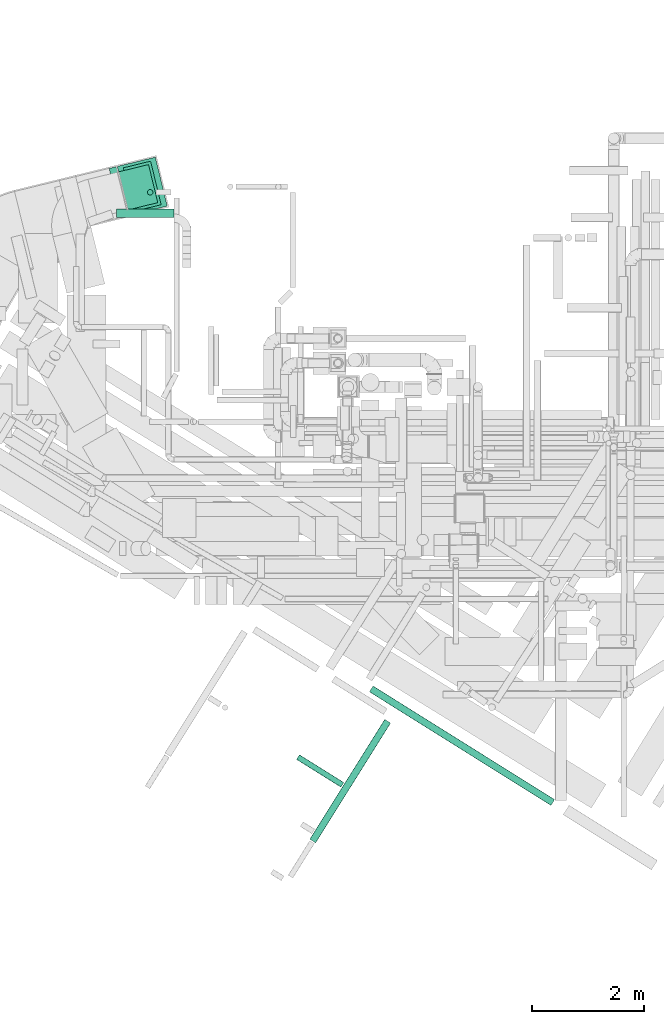
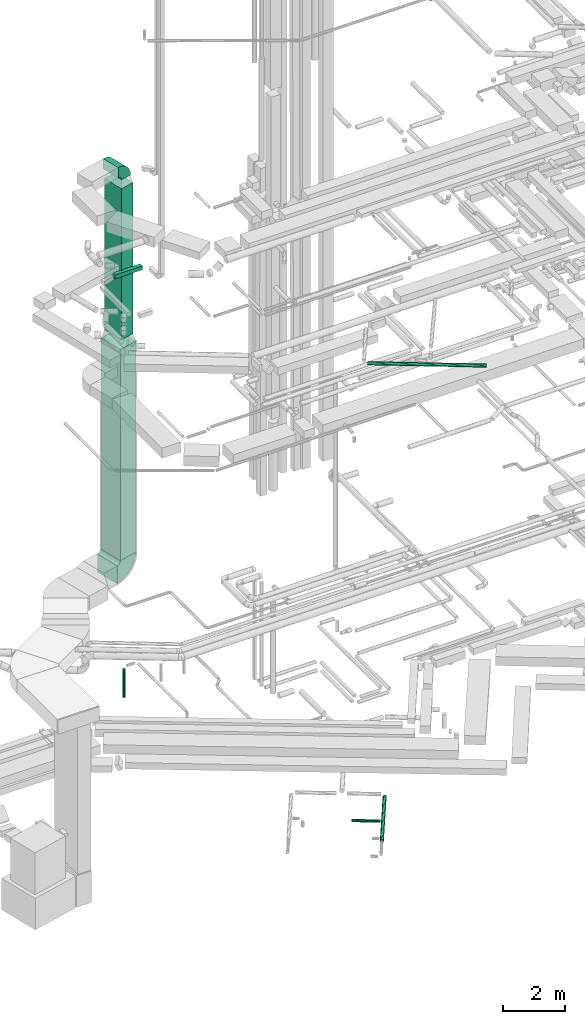
# One storey, part 24 of 337: 7 flow segments, 2 flow fittings.
"""IFC2X3 building model written with IfcOpenShell, lengths in millimetres."""

from ifc_helpers import new_model, entity, si_unit, converted_unit, derived_unit, direction, frame, frame_2d, origin, origin_2d_with_axis, place, context, subcontext, project, spatial, polyline, circle_curve, parameter, trimmed, segment, composite_curve, rectangle, circle, outline, extrude, source, transform, mapped, material, type_object, type_shapes, element, save


model = new_model("IFC2X3")

# Units and contexts
model_context = context("Model", 3, precision=0.01, world=origin(), true_north=direction((6.12303176911189e-17, 1.0)))
body_context = subcontext(model_context, "Body", "Model", "MODEL_VIEW")
ifc_project = project(units=[si_unit("LENGTHUNIT", "METRE", prefix="MILLI"), si_unit("AREAUNIT", "SQUARE_METRE"), si_unit("VOLUMEUNIT", "CUBIC_METRE"), converted_unit("PLANEANGLEUNIT", "DEGREE", entity("IfcRatioMeasure", 0.0174532925199433), si_unit("PLANEANGLEUNIT", "RADIAN"), dimensions=[0, 0, 0, 0, 0, 0, 0]), si_unit("MASSUNIT", "GRAM", prefix="KILO"), derived_unit("MASSDENSITYUNIT", [(si_unit("MASSUNIT", "GRAM", prefix="KILO"), 1), (si_unit("LENGTHUNIT", "METRE"), -3)]), derived_unit("MOMENTOFINERTIAUNIT", [(si_unit("LENGTHUNIT", "METRE"), 4)]), si_unit("TIMEUNIT", "SECOND"), si_unit("FREQUENCYUNIT", "HERTZ"), si_unit("THERMODYNAMICTEMPERATUREUNIT", "DEGREE_CELSIUS"), derived_unit("THERMALTRANSMITTANCEUNIT", [(si_unit("MASSUNIT", "GRAM", prefix="KILO"), 1), (si_unit("THERMODYNAMICTEMPERATUREUNIT", "KELVIN"), -1), (si_unit("TIMEUNIT", "SECOND"), -3)]), derived_unit("VOLUMETRICFLOWRATEUNIT", [(si_unit("LENGTHUNIT", "METRE"), 3), (si_unit("TIMEUNIT", "SECOND"), -1)]), derived_unit("MASSFLOWRATEUNIT", [(si_unit("MASSUNIT", "GRAM", prefix="KILO"), 1), (si_unit("TIMEUNIT", "SECOND"), -1)]), derived_unit("ROTATIONALFREQUENCYUNIT", [(si_unit("TIMEUNIT", "SECOND"), -1)]), si_unit("ELECTRICCURRENTUNIT", "AMPERE"), si_unit("ELECTRICVOLTAGEUNIT", "VOLT"), si_unit("POWERUNIT", "WATT"), si_unit("FORCEUNIT", "NEWTON", prefix="KILO"), si_unit("ILLUMINANCEUNIT", "LUX"), si_unit("LUMINOUSFLUXUNIT", "LUMEN"), si_unit("LUMINOUSINTENSITYUNIT", "CANDELA"), derived_unit("USERDEFINED", [(si_unit("MASSUNIT", "GRAM", prefix="KILO"), -1), (si_unit("LENGTHUNIT", "METRE"), -2), (si_unit("TIMEUNIT", "SECOND"), 3), (si_unit("LUMINOUSFLUXUNIT", "LUMEN"), 1)]), derived_unit("LINEARVELOCITYUNIT", [(si_unit("LENGTHUNIT", "METRE"), 1), (si_unit("TIMEUNIT", "SECOND"), -1)]), si_unit("PRESSUREUNIT", "PASCAL"), derived_unit("USERDEFINED", [(si_unit("LENGTHUNIT", "METRE"), -2), (si_unit("MASSUNIT", "GRAM", prefix="KILO"), 1), (si_unit("TIMEUNIT", "SECOND"), -2)]), derived_unit("LINEARFORCEUNIT", [(si_unit("MASSUNIT", "GRAM", prefix="KILO"), 1), (si_unit("LENGTHUNIT", "METRE"), 1), (si_unit("TIMEUNIT", "SECOND"), -2), (si_unit("LENGTHUNIT", "METRE"), -1)]), derived_unit("PLANARFORCEUNIT", [(si_unit("MASSUNIT", "GRAM", prefix="KILO"), 1), (si_unit("LENGTHUNIT", "METRE"), 1), (si_unit("TIMEUNIT", "SECOND"), -2), (si_unit("LENGTHUNIT", "METRE"), -2)])], contexts=[model_context])

# Site, building, storey
site_placement = place(None, origin())
site = spatial("IfcSite", under=ifc_project, at=site_placement, CompositionType="ELEMENT")
building_placement = place(site_placement, origin())
building = spatial("IfcBuilding", under=site, at=building_placement, CompositionType="ELEMENT")
storey_placement = place(building_placement, origin())
storey = spatial("IfcBuildingStorey", under=building, at=storey_placement, CompositionType="ELEMENT", Elevation=0.0)

# Flow segments
duct_segment_type_1 = type_object("IfcDuctSegmentType", PredefinedType="NOTDEFINED")
flow_segment_1_placement = place(storey_placement, frame((4083.1, 16997.5, 3950.0)))
element("IfcFlowSegment", 1, at=flow_segment_1_placement, inside=storey, type_object=duct_segment_type_1, context=body_context, shape_type="SweptSolid", body=[
    extrude(rectangle(XDim=699.999999999999, YDim=899.999999999999, at=origin_2d_with_axis()), frame((446.61, 520.09, 0.0), z_axis=(0.0, 0.0, 1.0), x_axis=(-0.971552058141474, -0.236826092990332, 0.0)), (0.0, 0.0, 1.0), 8300.00000000007),
])
flow_segment_2_placement = place(storey_placement, frame((4192.1, 17069.76, 12550.0)))
element("IfcFlowSegment", 2, at=flow_segment_2_placement, inside=storey, type_object=duct_segment_type_1, context=body_context, shape_type="SweptSolid", body=[
    extrude(rectangle(XDim=799.999999999999, YDim=500.0, at=origin_2d_with_axis()), frame((337.62, 447.83, 0.0), z_axis=(0.0, 0.0, 1.0), x_axis=(0.236826092990334, -0.971552058141474, 0.0)), (0.0, 0.0, 1.0), 5949.99999999992),
])
flow_segment_3_placement = place(storey_placement, frame((4066.87, 16960.58, 15125.0)))
element("IfcFlowSegment", 3, at=flow_segment_3_placement, inside=storey, type_object=duct_segment_type_1, context=body_context, shape_type="SweptSolid", body=[
    extrude(rectangle(XDim=1032.92560943049, YDim=150.000000000001, at=origin_2d_with_axis()), frame((516.46, 75.0, 0.0), z_axis=(0.0, 0.0, 1.0), x_axis=(-1.0, 0.0, 0.0)), (0.0, 0.0, 1.0), 150.000000000001),
])
duct_segment_type_2 = type_object("IfcDuctSegmentType", PredefinedType="NOTDEFINED")
flow_segment_4_placement = place(storey_placement, frame((4619.42, 17357.26, -1800.0)))
element("IfcFlowSegment", 4, at=flow_segment_4_placement, inside=storey, type_object=duct_segment_type_2, context=body_context, shape_type="SweptSolid", body=[
    extrude(circle(Radius=50.0, at=origin_2d_with_axis()), frame((51.6, 51.6, 0.0), z_axis=(0.0, 0.0, 1.0), x_axis=(0.0, -1.0, 0.0)), (0.0, 0.0, 1.0), 1100.00000000001),
])
flow_segment_5_placement = place(storey_placement, frame((7519.16, 5790.74, -1534.1)))
element("IfcFlowSegment", 5, at=flow_segment_5_placement, inside=storey, type_object=duct_segment_type_2, context=body_context, shape_type="SweptSolid", body=[
    extrude(circle(Radius=62.5, at=origin_2d_with_axis()), frame((54.58, 34.75, 64.1), z_axis=(0.530465285602536, 0.847706659623846, 0.0), x_axis=(-0.847706659623846, 0.530465285602536, 0.0)), (0.0, 0.0, 1.0), 2523.05389240172),
])
flow_segment_6_placement = place(storey_placement, frame((7281.16, 6783.64, -1521.6)))
element("IfcFlowSegment", 6, at=flow_segment_6_placement, inside=storey, type_object=duct_segment_type_2, context=body_context, shape_type="SweptSolid", body=[
    extrude(circle(Radius=50.0, at=origin_2d_with_axis()), frame((28.09, 540.28, 51.6), z_axis=(0.848052743777572, -0.529911826412029, 0.0), x_axis=(0.529911826412029, 0.848052743777572, 0.0)), (0.0, 0.0, 1.0), 936.535742155169),
])
flow_segment_7_placement = place(storey_placement, frame((8583.37, 6458.27, 15260.9)))
element("IfcFlowSegment", 7, at=flow_segment_7_placement, inside=storey, type_object=duct_segment_type_2, context=body_context, shape_type="SweptSolid", body=[
    extrude(circle(Radius=62.5, at=origin_2d_with_axis()), frame((34.75, 2083.3, 64.1), z_axis=(0.847731813922807, -0.530425085816224, 0.0), x_axis=(-0.530425085816224, -0.847731813922807, 0.0)), (0.0, 0.0, 1.0), 3824.70017723322),
])

# Flow fittings
ifc_material = material()
duct_fitting_type_1 = type_object("IfcDuctFittingType", PredefinedType="NOTDEFINED", material=ifc_material)
shared_shape_1 = source(origin(), body_context, "Body", "SweptSolid", [
    extrude(outline(composite_curve([segment(polyline([(-600.0, -250.0), (100.0, -250.0)]), True, "CONTINUOUS"), segment(trimmed(circle_curve(frame_2d((250.0, -250.0), x_axis=(0.0, 1.0)), 150.0), [parameter(0.0)], [parameter(90.0000000000001)], True, "PARAMETER"), False, "CONTINUOUS"), segment(polyline([(250.0, -100.0), (250.0, 600.0)]), True, "CONTINUOUS"), segment(trimmed(circle_curve(frame_2d((250.0, -250.0), x_axis=(0.0, 1.0)), 850.0), [parameter(0.0)], [parameter(90.0)], True, "PARAMETER"), True, "CONTINUOUS")], self_intersect=False)), frame((-250.0, 250.0, -450.0), z_axis=(0.0, 0.0, 1.0), x_axis=(-1.0, 0.0, 0.0)), (0.0, 0.0, 1.0), 900.0),
])
type_shapes(duct_fitting_type_1, [shared_shape_1])
flow_fitting_1_placement = place(storey_placement, frame((4529.72, 17517.59, 3450.0), z_axis=(0.236826092990338, -0.971552058141473, 0.0), x_axis=(0.971552058141473, 0.236826092990338, 0.0)))
element("IfcFlowFitting", 8, at=flow_fitting_1_placement, inside=storey, type_object=duct_fitting_type_1, material=ifc_material, context=body_context, shape_type="MappedRepresentation", body=[
    mapped(shared_shape_1, transform((0.0, 0.0, 0.0), scale=1.0)),
])
duct_fitting_type_2 = type_object("IfcDuctFittingType", PredefinedType="NOTDEFINED", material=ifc_material)
shared_shape_2 = source(origin(), body_context, "Body", "SweptSolid", [
    extrude(outline(composite_curve([segment(polyline([(-375.0, -175.0), (25.0, -175.0)]), True, "CONTINUOUS"), segment(trimmed(circle_curve(frame_2d((175.0, -175.0), x_axis=(0.0, 1.0)), 150.0), [parameter(0.0)], [parameter(90.0000000000001)], True, "PARAMETER"), False, "CONTINUOUS"), segment(polyline([(175.0, -25.0), (175.0, 375.0)]), True, "CONTINUOUS"), segment(trimmed(circle_curve(frame_2d((175.0, -175.0), x_axis=(0.0, 1.0)), 550.0), [parameter(0.0)], [parameter(90.0)], True, "PARAMETER"), True, "CONTINUOUS")], self_intersect=False)), frame((-175.0, 175.0, -350.0), z_axis=(0.0, 0.0, 1.0), x_axis=(-1.0, 0.0, 0.0)), (0.0, 0.0, 1.0), 700.0),
])
type_shapes(duct_fitting_type_2, [shared_shape_2])
flow_fitting_2_placement = place(storey_placement, frame((4529.72, 17517.59, 19150.0), z_axis=(0.236826092990335, -0.971552058141474, 0.0), x_axis=(0.0, 0.0, 1.0)))
element("IfcFlowFitting", 9, at=flow_fitting_2_placement, inside=storey, type_object=duct_fitting_type_2, material=ifc_material, context=body_context, shape_type="MappedRepresentation", body=[
    mapped(shared_shape_2, transform((0.0, 0.0, 0.0), scale=1.0)),
])

save(model, "model.ifc")
